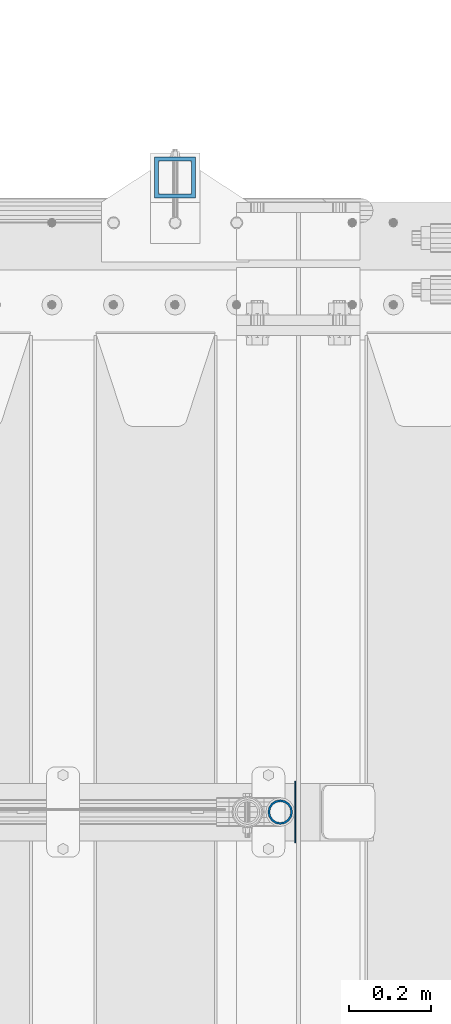
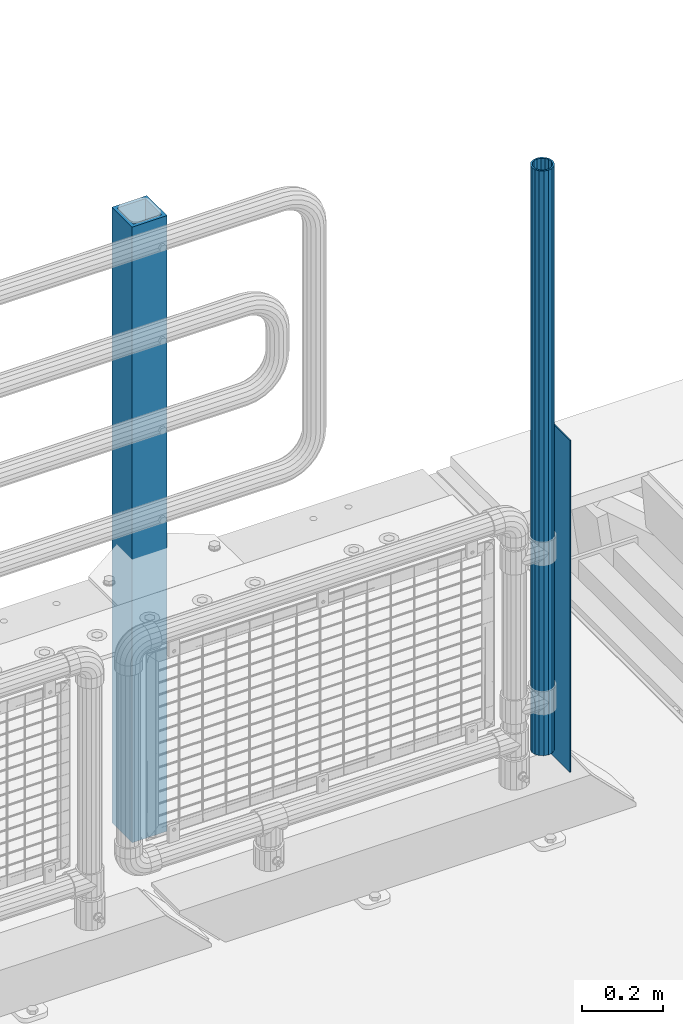
# One storey, part 59 of 242: 3 columns.
"""IFC2X3 building model written with IfcOpenShell, lengths in millimetres."""

from ifc_helpers import new_model, si_unit, frame, origin_with_axes, place, context, subcontext, project, spatial, faceted_brep, material, type_object, element, save


model = new_model("IFC2X3")

# Units and contexts
model_context = context("Model", 3, precision=1e-05, world=origin_with_axes())
body_context = subcontext(model_context, "Body", "Model", "MODEL_VIEW")
ifc_project = project(units=[si_unit("LENGTHUNIT", "METRE", prefix="MILLI"), si_unit("AREAUNIT", "SQUARE_METRE"), si_unit("VOLUMEUNIT", "CUBIC_METRE"), si_unit("MASSUNIT", "GRAM", prefix="KILO"), si_unit("TIMEUNIT", "SECOND"), si_unit("PLANEANGLEUNIT", "RADIAN"), si_unit("SOLIDANGLEUNIT", "STERADIAN"), si_unit("THERMODYNAMICTEMPERATUREUNIT", "DEGREE_CELSIUS"), si_unit("LUMINOUSINTENSITYUNIT", "LUMEN")], contexts=[model_context])

# Site, building, storey
site_placement = place(None, origin_with_axes())
site = spatial("IfcSite", under=ifc_project, at=site_placement, CompositionType="ELEMENT")
building_placement = place(site_placement, origin_with_axes())
building = spatial("IfcBuilding", under=site, at=building_placement, Name="Standard", CompositionType="ELEMENT")
storey_placement = place(building_placement, origin_with_axes())
storey = spatial("IfcBuildingStorey", under=building, at=storey_placement, Name="Undefined", CompositionType="ELEMENT", Elevation=0.0)

# Columns
ifc_material_1 = material(Name="Misc_Undefined")
column_type_1 = type_object("IfcColumnType", PredefinedType="NOTDEFINED")
column_1_placement = place(storey_placement, frame((-22576.0, -19335.5, 238.020000000002), z_axis=(-1.0, 0.0, 0.0), x_axis=(0.0, 0.0, 1.0)))
element("IfcColumn", 1, at=column_1_placement, inside=storey, type_object=column_type_1, material=ifc_material_1, context=body_context, shape_type="Brep", body=[
    faceted_brep([(0.0, -25.3499999999985, 0.0), (0.0, -23.4203461491597, 9.70102501045403), (1761.98, -23.4203461491597, 9.70102501045403), (1761.98, -25.3499999999985, 0.0), (0.0, -17.9251569030785, 17.9251569030785), (1761.98, -17.9251569030785, 17.9251569030785), (0.0, -9.70102501045403, 23.4203461491597), (1761.98, -9.70102501045403, 23.4203461491597), (0.0, 0.0, 25.3499999999985), (1761.98, 0.0, 25.3499999999985), (0.0, 9.70102501045403, 23.4203461491597), (1761.98, 9.70102501045403, 23.4203461491597), (0.0, 17.9251569030785, 17.9251569030785), (1761.98, 17.9251569030785, 17.9251569030785), (0.0, 23.4203461491597, 9.70102501045403), (1761.98, 23.4203461491597, 9.70102501045403), (0.0, 25.3499999999985, 0.0), (1761.98, 25.3499999999985, 0.0), (0.0, 23.4203461491597, -9.70102501045403), (1761.98, 23.4203461491597, -9.70102501045403), (0.0, 17.9251569030785, -17.9251569030785), (1761.98, 17.9251569030785, -17.9251569030785), (0.0, 9.70102501045403, -23.4203461491597), (1761.98, 9.70102501045403, -23.4203461491597), (0.0, 0.0, -25.3499999999985), (1761.98, 0.0, -25.3499999999985), (0.0, -9.70102501045403, -23.4203461491597), (1761.98, -9.70102501045403, -23.4203461491597), (0.0, -17.9251569030785, -17.9251569030785), (1761.98, -17.9251569030785, -17.9251569030785), (0.0, -23.4203461491597, -9.70102501045403), (1761.98, -23.4203461491597, -9.70102501045403), (0.0, -30.1500000000015, 0.0), (0.0, -27.8549679052157, -11.5379054858058), (1761.98, -27.8549679052157, -11.5379054858058), (1761.98, -30.1500000000015, 0.0), (0.0, -21.3192694527752, -21.3192694527752), (1761.98, -21.3192694527752, -21.3192694527752), (0.0, -11.5379054858058, -27.8549679052157), (1761.98, -11.5379054858058, -27.8549679052157), (0.0, 0.0, -30.1500000000015), (1761.98, 0.0, -30.1500000000015), (0.0, 11.5379054858058, -27.8549679052157), (1761.98, 11.5379054858058, -27.8549679052157), (0.0, 21.3192694527752, -21.3192694527752), (1761.98, 21.3192694527752, -21.3192694527752), (0.0, 27.8549679052157, -11.5379054858058), (1761.98, 27.8549679052157, -11.5379054858058), (0.0, 30.1500000000015, 0.0), (1761.98, 30.1500000000015, 0.0), (0.0, 27.8549679052157, 11.5379054858058), (1761.98, 27.8549679052157, 11.5379054858058), (0.0, 21.3192694527752, 21.3192694527752), (1761.98, 21.3192694527752, 21.3192694527752), (0.0, 11.5379054858058, 27.8549679052157), (1761.98, 11.5379054858058, 27.8549679052157), (0.0, 0.0, 30.1500000000015), (1761.98, 0.0, 30.1500000000015), (0.0, -11.5379054858058, 27.8549679052157), (1761.98, -11.5379054858058, 27.8549679052157), (0.0, -21.3192694527752, 21.3192694527752), (1761.98, -21.3192694527752, 21.3192694527752), (0.0, -27.8549679052157, 11.5379054858058), (1761.98, -27.8549679052157, 11.5379054858058)], [[[0, 1, 2, 3]], [[1, 4, 5, 2]], [[4, 6, 7, 5]], [[6, 8, 9, 7]], [[8, 10, 11, 9]], [[10, 12, 13, 11]], [[12, 14, 15, 13]], [[14, 16, 17, 15]], [[16, 18, 19, 17]], [[18, 20, 21, 19]], [[20, 22, 23, 21]], [[22, 24, 25, 23]], [[24, 26, 27, 25]], [[26, 28, 29, 27]], [[28, 30, 31, 29]], [[30, 0, 3, 31]], [[32, 33, 34, 35]], [[33, 36, 37, 34]], [[36, 38, 39, 37]], [[38, 40, 41, 39]], [[40, 42, 43, 41]], [[42, 44, 45, 43]], [[44, 46, 47, 45]], [[46, 48, 49, 47]], [[48, 50, 51, 49]], [[50, 52, 53, 51]], [[52, 54, 55, 53]], [[54, 56, 57, 55]], [[56, 58, 59, 57]], [[58, 60, 61, 59]], [[60, 62, 63, 61]], [[62, 32, 35, 63]], [[37, 39, 41, 43, 45, 47, 49, 51, 53, 55, 57, 59, 61, 63, 35, 34], [5, 7, 9, 11, 13, 15, 17, 19, 21, 23, 25, 27, 29, 31, 3, 2]], [[62, 60, 58, 56, 54, 52, 50, 48, 46, 44, 42, 40, 38, 36, 33, 32], [30, 28, 26, 24, 22, 20, 18, 16, 14, 12, 10, 8, 6, 4, 1, 0]]]),
])
column_type_2 = type_object("IfcColumnType", PredefinedType="NOTDEFINED")
column_2_placement = place(storey_placement, frame((-22539.5, -19335.5, 200.000000000001), z_axis=(0.0, 1.0, 0.0), x_axis=(0.0, 0.0, 1.0)))
element("IfcColumn", 2, at=column_2_placement, inside=storey, type_object=column_type_2, material=ifc_material_1, context=body_context, shape_type="Brep", body=[
    faceted_brep([(0.0, 1.5, -75.0), (0.0, 1.5, 75.0), (1000.0, 1.5, 75.0), (1000.0, 1.5, -75.0), (0.0, -1.5, 75.0), (1000.0, -1.5, 75.0), (0.0, -1.5, -75.0), (1000.0, -1.5, -75.0)], [[[0, 1, 2, 3]], [[1, 4, 5, 2]], [[4, 6, 7, 5]], [[6, 0, 3, 7]], [[5, 7, 3, 2]], [[6, 4, 1, 0]]]),
])
ifc_material_2 = material()
column_type_3 = type_object("IfcColumnType", PredefinedType="NOTDEFINED")
column_3_placement = place(storey_placement, frame((-22831.9999999999, -17789.9999999998, -844.999999999998), z_axis=(0.0, -1.0, 0.0), x_axis=(0.0, 0.0, 1.0)))
element("IfcColumn", 3, at=column_3_placement, inside=storey, type_object=column_type_3, material=ifc_material_2, context=body_context, shape_type="Brep", body=[
    faceted_brep([(0.0, 40.0, -40.0), (0.0, -40.0, -40.0), (1855.0, -40.0, -40.0), (1855.0, 40.0, -40.0), (0.0, -40.0, 40.0), (1855.0, -40.0, 40.0), (0.0, 40.0, 40.0), (1855.0, 40.0, 40.0), (0.0, 50.0, -50.0), (0.0, 50.0, 50.0), (1855.0, 50.0, 50.0), (1855.0, 50.0, -50.0), (0.0, -50.0, 50.0), (1855.0, -50.0, 50.0), (0.0, -50.0, -50.0), (1855.0, -50.0, -50.0)], [[[0, 1, 2, 3]], [[1, 4, 5, 2]], [[4, 6, 7, 5]], [[6, 0, 3, 7]], [[8, 9, 10, 11]], [[9, 12, 13, 10]], [[12, 14, 15, 13]], [[14, 8, 11, 15]], [[13, 15, 11, 10], [5, 7, 3, 2]], [[14, 12, 9, 8], [6, 4, 1, 0]]]),
])

save(model, "model.ifc")
